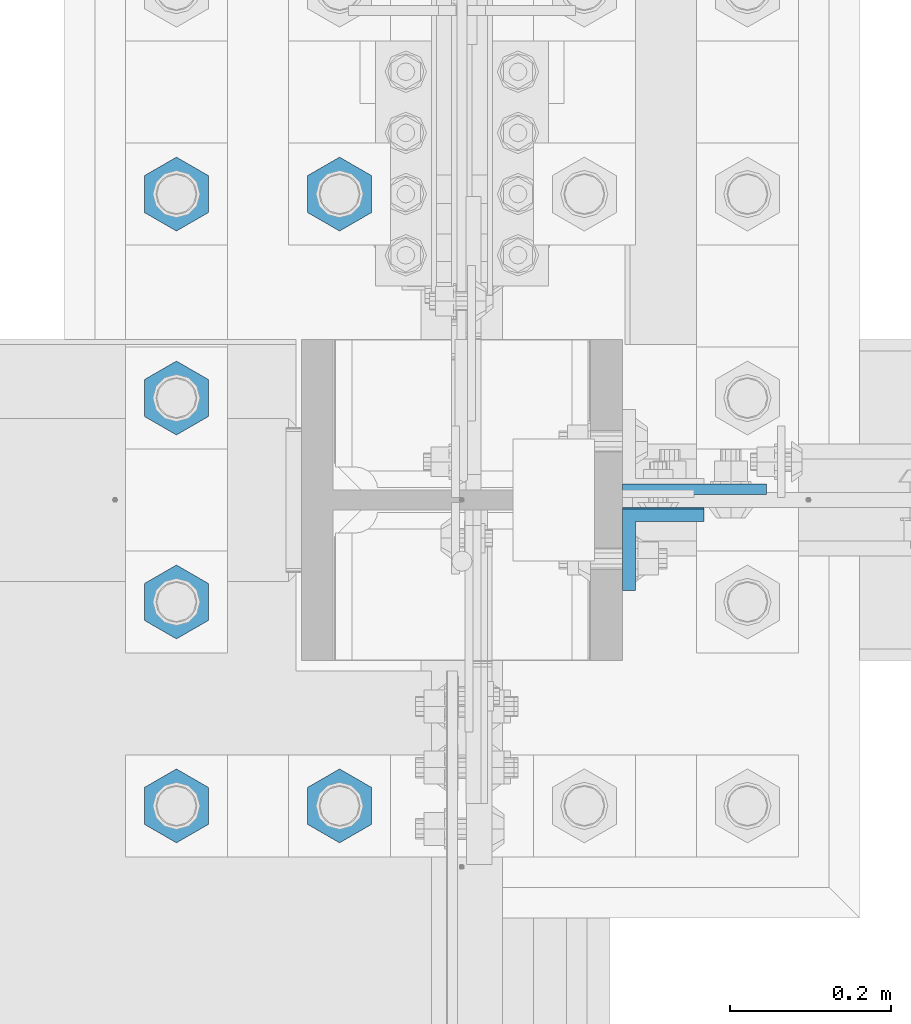
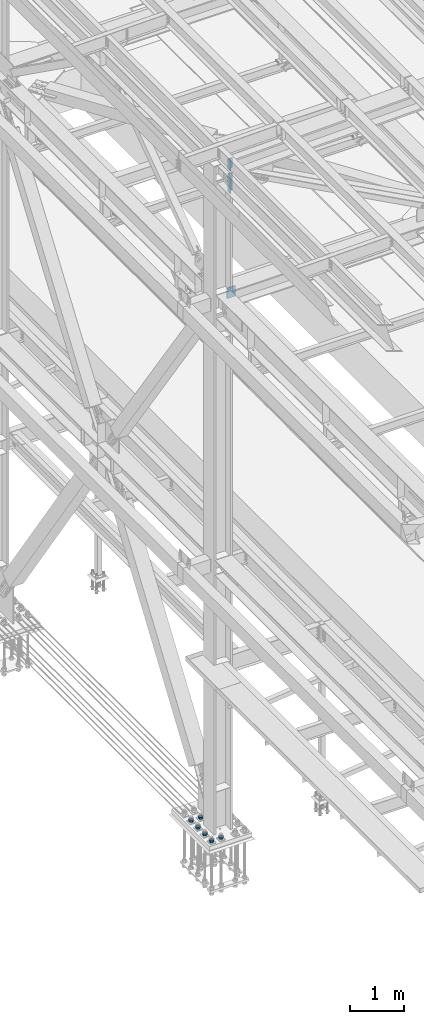
# One storey, part 1547 of 3843: 9 columns, 3 elements without a shape of their own.
"""IFC2X3 building model written with IfcOpenShell, lengths in millimetres."""

from ifc_helpers import new_model, si_unit, frame, origin_with_axes, place, context, subcontext, project, spatial, faceted_brep, material, type_object, element, aggregate, save


model = new_model("IFC2X3")

# Units and contexts
model_context = context("Model", 3, precision=1e-05, world=origin_with_axes())
body_context = subcontext(model_context, "Body", "Model", "MODEL_VIEW")
ifc_project = project(units=[si_unit("LENGTHUNIT", "METRE", prefix="MILLI"), si_unit("AREAUNIT", "SQUARE_METRE"), si_unit("VOLUMEUNIT", "CUBIC_METRE"), si_unit("MASSUNIT", "GRAM", prefix="KILO"), si_unit("TIMEUNIT", "SECOND"), si_unit("PLANEANGLEUNIT", "RADIAN"), si_unit("SOLIDANGLEUNIT", "STERADIAN"), si_unit("THERMODYNAMICTEMPERATUREUNIT", "DEGREE_CELSIUS"), si_unit("LUMINOUSINTENSITYUNIT", "LUMEN")], contexts=[model_context])

# Site, building, storey
site_placement = place(None, origin_with_axes())
site = spatial("IfcSite", under=ifc_project, at=site_placement, CompositionType="ELEMENT")
building_placement = place(site_placement, origin_with_axes())
building = spatial("IfcBuilding", under=site, at=building_placement, Name="Undefined", CompositionType="ELEMENT")
storey_placement = place(building_placement, origin_with_axes())
storey = spatial("IfcBuildingStorey", under=building, at=storey_placement, Name="Undefined", CompositionType="ELEMENT", Elevation=0.0)

# Assembly, columns
assembly_1_placement = place(storey_placement, origin_with_axes())
assembly_1 = element("IfcElementAssembly", 1, at=assembly_1_placement, inside=storey, Name="BEAM", AssemblyPlace="NOTDEFINED", PredefinedType="RIGID_FRAME")
ifc_material = material(Name="STEEL/A572-50")
column_type_1 = type_object("IfcColumnType", Name="L4X4X5/8", PredefinedType="NOTDEFINED")
column_1_placement = place(assembly_1_placement, frame((36826.8250000141, 67209.9879995346, 45113.5459635213), z_axis=(0.0, -1.0, 0.0), x_axis=(0.0, 0.0, 1.0)))
column_1 = element("IfcColumn", 2, at=column_1_placement, type_object=column_type_1, material=ifc_material, Name="ANGLE", ObjectType="L4X4X5/8", context=body_context, shape_type="Brep", body=[
    faceted_brep([(0.0, 50.8000000000029, -50.8000000000029), (0.0, 50.8000000000029, 50.8000000000029), (228.600164820818, 50.8000000000029, 50.8000000000029), (228.600164820818, 50.8000000000029, -50.8000000000029), (0.0, 34.9250000000029, 50.8000000000029), (228.600164820818, 34.9250000000029, 50.8000000000029), (0.0, 34.9250000000029, -34.9250000000029), (228.600164820818, 34.9250000000029, -34.9250000000029), (0.0, -50.8000000000029, -34.9250000000029), (228.600164820818, -50.8000000000029, -34.9250000000029), (0.0, -50.8000000000029, -50.8000000000029), (228.600164820818, -50.8000000000029, -50.8000000000029)], [[[0, 1, 2, 3]], [[1, 4, 5, 2]], [[4, 6, 7, 5]], [[6, 8, 9, 7]], [[8, 10, 11, 9]], [[10, 0, 3, 11]], [[5, 7, 9, 11, 3, 2]], [[10, 8, 6, 4, 1, 0]]]),
])
column_2_placement = place(assembly_1_placement, frame((36826.8249999999, 67211.5750003815, 44597.8922976153), z_axis=(0.0, -1.0, 0.0), x_axis=(0.0, 0.0, 1.0)))
column_2 = element("IfcColumn", 3, at=column_2_placement, type_object=column_type_1, material=ifc_material, Name="ANGLE", ObjectType="L4X4X5/8", context=body_context, shape_type="Brep", body=[
    faceted_brep([(0.0, 50.8000000000029, -50.8000000000029), (0.0, 50.8000000000029, 50.8000000000029), (406.399999999841, 50.799999998344, 50.8000000000029), (406.399999999841, 50.799999998344, -50.8000000000029), (0.0, 34.9250000000029, 50.8000000000029), (406.399999999892, 34.924999998344, 50.8000000000029), (0.0, 34.9250000000029, -34.9250000000029), (406.399999999892, 34.924999998344, -34.9250000000029), (0.0, -50.8000000000029, -34.9250000000029), (406.400000000162, -50.8000000016473, -34.9250000000029), (0.0, -50.8000000000029, -50.8000000000029), (406.400000000162, -50.8000000016473, -50.8000000000029)], [[[0, 1, 2, 3]], [[1, 4, 5, 2]], [[4, 6, 7, 5]], [[6, 8, 9, 7]], [[8, 10, 11, 9]], [[10, 0, 3, 11]], [[5, 7, 9, 11, 3, 2]], [[10, 8, 6, 4, 1, 0]]]),
])
aggregate(assembly_1, [column_1, column_2])

# Assembly, column
assembly_2_placement = place(storey_placement, origin_with_axes())
assembly_2 = element("IfcElementAssembly", 4, at=assembly_2_placement, inside=storey, Name="COLUMN", AssemblyPlace="NOTDEFINED", PredefinedType="RIGID_FRAME")
column_type_2 = type_object("IfcColumnType", PredefinedType="NOTDEFINED")
column_3_placement = place(assembly_2_placement, frame((36865.6955000011, 67285.39375, 42133.8327920583), z_axis=(-1.0, 0.0, 0.0), x_axis=(0.0, 0.0, 1.0)))
column_3 = element("IfcColumn", 5, at=column_3_placement, type_object=column_type_2, material=ifc_material, Name="PLATE", context=body_context, shape_type="Brep", body=[
    faceted_brep([(0.0, 6.35000000000582, -89.6705000000002), (0.0, 6.35000000000582, 89.6705000000002), (241.299999999996, 6.35000000000582, 89.6705000000002), (241.299999999996, 6.35000000000582, -89.6705000000002), (0.0, -6.35000000000582, 89.6705000000002), (241.299999999996, -6.35000000000582, 89.6705000000002), (0.0, -6.35000000000582, -89.6705000000002), (241.299999999996, -6.35000000000582, -89.6705000000002)], [[[0, 1, 2, 3]], [[1, 4, 5, 2]], [[4, 6, 7, 5]], [[6, 0, 3, 7]], [[5, 7, 3, 2]], [[6, 4, 1, 0]]]),
])
aggregate(assembly_2, [column_3])

# Assembly, columns
assembly_3_placement = place(storey_placement, origin_with_axes())
assembly_3 = element("IfcElementAssembly", 6, at=assembly_3_placement, inside=storey, Name="TEMPLATE", AssemblyPlace="NOTDEFINED", PredefinedType="RIGID_FRAME")
column_type_3 = type_object("IfcColumnType", Name="2_HEAVY_HEX_NUT", PredefinedType="NOTDEFINED")
column_4_placement = place(assembly_3_placement, frame((36423.6, 66890.9, 30232.35), z_axis=(1.0, 0.0, 0.0), x_axis=(0.0, 0.0, -1.0)))
column_4 = element("IfcColumn", 7, at=column_4_placement, type_object=column_type_3, material=ifc_material, Name="NUT", ObjectType="2_HEAVY_HEX_NUT", context=body_context, shape_type="Brep", body=[
    faceted_brep([(0.0, -46.0369987487793, 0.0), (0.0, -23.0184993743896, -39.869213104248), (50.7999999999993, -23.0184993743896, -39.869213104248), (50.7999999999993, -46.0369987487793, 0.0), (0.0, 23.0184993743896, -39.869213104248), (50.7999999999993, 23.0184993743896, -39.869213104248), (0.0, 46.0369987487793, 0.0), (50.7999999999993, 46.0369987487793, 0.0), (0.0, 23.0184993743896, 39.869213104248), (50.7999999999993, 23.0184993743896, 39.869213104248), (0.0, -23.0184993743896, 39.869213104248), (50.7999999999993, -23.0184993743896, 39.869213104248), (0.0, 0.0, 26.1940002441406), (0.0, 11.3650617044477, 23.5999013092805), (50.7999999999993, 11.3650617044477, 23.5999013092805), (50.7999999999993, 0.0, 26.1940002441406), (0.0, 20.4791109456419, 16.3316083006721), (50.7999999999993, 20.4791109456419, 16.3316083006721), (0.0, 25.5370200498292, 5.82867859874386), (50.7999999999993, 25.5370200498292, 5.82867859874386), (0.0, 25.5370200498292, -5.82867859874386), (50.7999999999993, 25.5370200498292, -5.82867859874386), (0.0, 20.4791109456419, -16.3316083006721), (50.7999999999993, 20.4791109456419, -16.3316083006721), (0.0, 11.3650617044477, -23.5999013092805), (50.7999999999993, 11.3650617044477, -23.5999013092805), (0.0, 0.0, -26.1940002441406), (50.7999999999993, 0.0, -26.1940002441406), (0.0, -11.3650617044477, -23.5999013092805), (50.7999999999993, -11.3650617044477, -23.5999013092805), (0.0, -20.4791109456419, -16.3316083006721), (50.7999999999993, -20.4791109456419, -16.3316083006721), (0.0, -25.5370200498292, -5.82867859874386), (50.7999999999993, -25.5370200498292, -5.82867859874386), (0.0, -25.5370200498292, 5.82867859874386), (50.7999999999993, -25.5370200498292, 5.82867859874386), (0.0, -20.4791109456419, 16.3316083006721), (50.7999999999993, -20.4791109456419, 16.3316083006721), (0.0, -11.3650617044477, 23.5999013092805), (50.7999999999993, -11.3650617044477, 23.5999013092805)], [[[0, 1, 2, 3]], [[1, 4, 5, 2]], [[4, 6, 7, 5]], [[6, 8, 9, 7]], [[8, 10, 11, 9]], [[10, 0, 3, 11]], [[12, 13, 14, 15]], [[13, 16, 17, 14]], [[16, 18, 19, 17]], [[18, 20, 21, 19]], [[20, 22, 23, 21]], [[22, 24, 25, 23]], [[24, 26, 27, 25]], [[26, 28, 29, 27]], [[28, 30, 31, 29]], [[30, 32, 33, 31]], [[32, 34, 35, 33]], [[34, 36, 37, 35]], [[36, 38, 39, 37]], [[38, 12, 15, 39]], [[5, 7, 9, 11, 3, 2], [17, 19, 21, 23, 25, 27, 29, 31, 33, 35, 37, 39, 15, 14]], [[10, 8, 6, 4, 1, 0], [38, 36, 34, 32, 30, 28, 26, 24, 22, 20, 18, 16, 13, 12]]]),
])
column_5_placement = place(assembly_3_placement, frame((36423.6, 67652.9, 30232.35), z_axis=(-1.0, 0.0, 0.0), x_axis=(0.0, 0.0, -1.0)))
column_5 = element("IfcColumn", 8, at=column_5_placement, type_object=column_type_3, material=ifc_material, Name="NUT", ObjectType="2_HEAVY_HEX_NUT", context=body_context, shape_type="Brep", body=[
    faceted_brep([(0.0, -46.0369987487793, 0.0), (0.0, -23.0184993743896, -39.869213104248), (50.7999999999993, -23.0184993743896, -39.869213104248), (50.7999999999993, -46.0369987487793, 0.0), (0.0, 23.0184993743896, -39.869213104248), (50.7999999999993, 23.0184993743896, -39.869213104248), (0.0, 46.0369987487793, 0.0), (50.7999999999993, 46.0369987487793, 0.0), (0.0, 23.0184993743896, 39.869213104248), (50.7999999999993, 23.0184993743896, 39.869213104248), (0.0, -23.0184993743896, 39.869213104248), (50.7999999999993, -23.0184993743896, 39.869213104248), (0.0, 0.0, 26.1940002441406), (0.0, 11.3650617044477, 23.5999013092805), (50.7999999999993, 11.3650617044477, 23.5999013092805), (50.7999999999993, 0.0, 26.1940002441406), (0.0, 20.4791109456419, 16.3316083006721), (50.7999999999993, 20.4791109456419, 16.3316083006721), (0.0, 25.5370200498292, 5.82867859874386), (50.7999999999993, 25.5370200498292, 5.82867859874386), (0.0, 25.5370200498292, -5.82867859874386), (50.7999999999993, 25.5370200498292, -5.82867859874386), (0.0, 20.4791109456419, -16.3316083006721), (50.7999999999993, 20.4791109456419, -16.3316083006721), (0.0, 11.3650617044477, -23.5999013092805), (50.7999999999993, 11.3650617044477, -23.5999013092805), (0.0, 0.0, -26.1940002441406), (50.7999999999993, 0.0, -26.1940002441406), (0.0, -11.3650617044477, -23.5999013092805), (50.7999999999993, -11.3650617044477, -23.5999013092805), (0.0, -20.4791109456419, -16.3316083006721), (50.7999999999993, -20.4791109456419, -16.3316083006721), (0.0, -25.5370200498292, -5.82867859874386), (50.7999999999993, -25.5370200498292, -5.82867859874386), (0.0, -25.5370200498292, 5.82867859874386), (50.7999999999993, -25.5370200498292, 5.82867859874386), (0.0, -20.4791109456419, 16.3316083006721), (50.7999999999993, -20.4791109456419, 16.3316083006721), (0.0, -11.3650617044477, 23.5999013092805), (50.7999999999993, -11.3650617044477, 23.5999013092805)], [[[0, 1, 2, 3]], [[1, 4, 5, 2]], [[4, 6, 7, 5]], [[6, 8, 9, 7]], [[8, 10, 11, 9]], [[10, 0, 3, 11]], [[12, 13, 14, 15]], [[13, 16, 17, 14]], [[16, 18, 19, 17]], [[18, 20, 21, 19]], [[20, 22, 23, 21]], [[22, 24, 25, 23]], [[24, 26, 27, 25]], [[26, 28, 29, 27]], [[28, 30, 31, 29]], [[30, 32, 33, 31]], [[32, 34, 35, 33]], [[34, 36, 37, 35]], [[36, 38, 39, 37]], [[38, 12, 15, 39]], [[5, 7, 9, 11, 3, 2], [17, 19, 21, 23, 25, 27, 29, 31, 33, 35, 37, 39, 15, 14]], [[10, 8, 6, 4, 1, 0], [38, 36, 34, 32, 30, 28, 26, 24, 22, 20, 18, 16, 13, 12]]]),
])
column_6_placement = place(assembly_3_placement, frame((36220.4, 66890.9, 30232.35), z_axis=(1.0, 0.0, 0.0), x_axis=(0.0, 0.0, -1.0)))
column_6 = element("IfcColumn", 9, at=column_6_placement, type_object=column_type_3, material=ifc_material, Name="NUT", ObjectType="2_HEAVY_HEX_NUT", context=body_context, shape_type="Brep", body=[
    faceted_brep([(0.0, -46.0369987487793, 0.0), (0.0, -23.0184993743896, -39.869213104248), (50.7999999999993, -23.0184993743896, -39.869213104248), (50.7999999999993, -46.0369987487793, 0.0), (0.0, 23.0184993743896, -39.869213104248), (50.7999999999993, 23.0184993743896, -39.869213104248), (0.0, 46.0369987487793, 0.0), (50.7999999999993, 46.0369987487793, 0.0), (0.0, 23.0184993743896, 39.869213104248), (50.7999999999993, 23.0184993743896, 39.869213104248), (0.0, -23.0184993743896, 39.869213104248), (50.7999999999993, -23.0184993743896, 39.869213104248), (0.0, 0.0, 26.1940002441406), (0.0, 11.3650617044477, 23.5999013092805), (50.7999999999993, 11.3650617044477, 23.5999013092805), (50.7999999999993, 0.0, 26.1940002441406), (0.0, 20.4791109456419, 16.3316083006721), (50.7999999999993, 20.4791109456419, 16.3316083006721), (0.0, 25.5370200498292, 5.82867859874386), (50.7999999999993, 25.5370200498292, 5.82867859874386), (0.0, 25.5370200498292, -5.82867859874386), (50.7999999999993, 25.5370200498292, -5.82867859874386), (0.0, 20.4791109456419, -16.3316083006721), (50.7999999999993, 20.4791109456419, -16.3316083006721), (0.0, 11.3650617044477, -23.5999013092805), (50.7999999999993, 11.3650617044477, -23.5999013092805), (0.0, 0.0, -26.1940002441406), (50.7999999999993, 0.0, -26.1940002441406), (0.0, -11.3650617044477, -23.5999013092805), (50.7999999999993, -11.3650617044477, -23.5999013092805), (0.0, -20.4791109456419, -16.3316083006721), (50.7999999999993, -20.4791109456419, -16.3316083006721), (0.0, -25.5370200498292, -5.82867859874386), (50.7999999999993, -25.5370200498292, -5.82867859874386), (0.0, -25.5370200498292, 5.82867859874386), (50.7999999999993, -25.5370200498292, 5.82867859874386), (0.0, -20.4791109456419, 16.3316083006721), (50.7999999999993, -20.4791109456419, 16.3316083006721), (0.0, -11.3650617044477, 23.5999013092805), (50.7999999999993, -11.3650617044477, 23.5999013092805)], [[[0, 1, 2, 3]], [[1, 4, 5, 2]], [[4, 6, 7, 5]], [[6, 8, 9, 7]], [[8, 10, 11, 9]], [[10, 0, 3, 11]], [[12, 13, 14, 15]], [[13, 16, 17, 14]], [[16, 18, 19, 17]], [[18, 20, 21, 19]], [[20, 22, 23, 21]], [[22, 24, 25, 23]], [[24, 26, 27, 25]], [[26, 28, 29, 27]], [[28, 30, 31, 29]], [[30, 32, 33, 31]], [[32, 34, 35, 33]], [[34, 36, 37, 35]], [[36, 38, 39, 37]], [[38, 12, 15, 39]], [[5, 7, 9, 11, 3, 2], [17, 19, 21, 23, 25, 27, 29, 31, 33, 35, 37, 39, 15, 14]], [[10, 8, 6, 4, 1, 0], [38, 36, 34, 32, 30, 28, 26, 24, 22, 20, 18, 16, 13, 12]]]),
])
column_7_placement = place(assembly_3_placement, frame((36220.4, 67144.9, 30232.35), z_axis=(1.0, 0.0, 0.0), x_axis=(0.0, 0.0, -1.0)))
column_7 = element("IfcColumn", 10, at=column_7_placement, type_object=column_type_3, material=ifc_material, Name="NUT", ObjectType="2_HEAVY_HEX_NUT", context=body_context, shape_type="Brep", body=[
    faceted_brep([(0.0, -46.0369987487793, 0.0), (0.0, -23.0184993743896, -39.869213104248), (50.7999999999993, -23.0184993743896, -39.869213104248), (50.7999999999993, -46.0369987487793, 0.0), (0.0, 23.0184993743896, -39.869213104248), (50.7999999999993, 23.0184993743896, -39.869213104248), (0.0, 46.0369987487793, 0.0), (50.7999999999993, 46.0369987487793, 0.0), (0.0, 23.0184993743896, 39.869213104248), (50.7999999999993, 23.0184993743896, 39.869213104248), (0.0, -23.0184993743896, 39.869213104248), (50.7999999999993, -23.0184993743896, 39.869213104248), (0.0, 0.0, 26.1940002441406), (0.0, 11.3650617044477, 23.5999013092805), (50.7999999999993, 11.3650617044477, 23.5999013092805), (50.7999999999993, 0.0, 26.1940002441406), (0.0, 20.4791109456419, 16.3316083006721), (50.7999999999993, 20.4791109456419, 16.3316083006721), (0.0, 25.5370200498292, 5.82867859874386), (50.7999999999993, 25.5370200498292, 5.82867859874386), (0.0, 25.5370200498292, -5.82867859874386), (50.7999999999993, 25.5370200498292, -5.82867859874386), (0.0, 20.4791109456419, -16.3316083006721), (50.7999999999993, 20.4791109456419, -16.3316083006721), (0.0, 11.3650617044477, -23.5999013092805), (50.7999999999993, 11.3650617044477, -23.5999013092805), (0.0, 0.0, -26.1940002441406), (50.7999999999993, 0.0, -26.1940002441406), (0.0, -11.3650617044477, -23.5999013092805), (50.7999999999993, -11.3650617044477, -23.5999013092805), (0.0, -20.4791109456419, -16.3316083006721), (50.7999999999993, -20.4791109456419, -16.3316083006721), (0.0, -25.5370200498292, -5.82867859874386), (50.7999999999993, -25.5370200498292, -5.82867859874386), (0.0, -25.5370200498292, 5.82867859874386), (50.7999999999993, -25.5370200498292, 5.82867859874386), (0.0, -20.4791109456419, 16.3316083006721), (50.7999999999993, -20.4791109456419, 16.3316083006721), (0.0, -11.3650617044477, 23.5999013092805), (50.7999999999993, -11.3650617044477, 23.5999013092805)], [[[0, 1, 2, 3]], [[1, 4, 5, 2]], [[4, 6, 7, 5]], [[6, 8, 9, 7]], [[8, 10, 11, 9]], [[10, 0, 3, 11]], [[12, 13, 14, 15]], [[13, 16, 17, 14]], [[16, 18, 19, 17]], [[18, 20, 21, 19]], [[20, 22, 23, 21]], [[22, 24, 25, 23]], [[24, 26, 27, 25]], [[26, 28, 29, 27]], [[28, 30, 31, 29]], [[30, 32, 33, 31]], [[32, 34, 35, 33]], [[34, 36, 37, 35]], [[36, 38, 39, 37]], [[38, 12, 15, 39]], [[5, 7, 9, 11, 3, 2], [17, 19, 21, 23, 25, 27, 29, 31, 33, 35, 37, 39, 15, 14]], [[10, 8, 6, 4, 1, 0], [38, 36, 34, 32, 30, 28, 26, 24, 22, 20, 18, 16, 13, 12]]]),
])
column_8_placement = place(assembly_3_placement, frame((36220.4, 67398.9, 30232.35), z_axis=(1.0, 0.0, 0.0), x_axis=(0.0, 0.0, -1.0)))
column_8 = element("IfcColumn", 11, at=column_8_placement, type_object=column_type_3, material=ifc_material, Name="NUT", ObjectType="2_HEAVY_HEX_NUT", context=body_context, shape_type="Brep", body=[
    faceted_brep([(0.0, -46.0369987487793, 0.0), (0.0, -23.0184993743896, -39.869213104248), (50.7999999999993, -23.0184993743896, -39.869213104248), (50.7999999999993, -46.0369987487793, 0.0), (0.0, 23.0184993743896, -39.869213104248), (50.7999999999993, 23.0184993743896, -39.869213104248), (0.0, 46.0369987487793, 0.0), (50.7999999999993, 46.0369987487793, 0.0), (0.0, 23.0184993743896, 39.869213104248), (50.7999999999993, 23.0184993743896, 39.869213104248), (0.0, -23.0184993743896, 39.869213104248), (50.7999999999993, -23.0184993743896, 39.869213104248), (0.0, 0.0, 26.1940002441406), (0.0, 11.3650617044477, 23.5999013092805), (50.7999999999993, 11.3650617044477, 23.5999013092805), (50.7999999999993, 0.0, 26.1940002441406), (0.0, 20.4791109456419, 16.3316083006721), (50.7999999999993, 20.4791109456419, 16.3316083006721), (0.0, 25.5370200498292, 5.82867859874386), (50.7999999999993, 25.5370200498292, 5.82867859874386), (0.0, 25.5370200498292, -5.82867859874386), (50.7999999999993, 25.5370200498292, -5.82867859874386), (0.0, 20.4791109456419, -16.3316083006721), (50.7999999999993, 20.4791109456419, -16.3316083006721), (0.0, 11.3650617044477, -23.5999013092805), (50.7999999999993, 11.3650617044477, -23.5999013092805), (0.0, 0.0, -26.1940002441406), (50.7999999999993, 0.0, -26.1940002441406), (0.0, -11.3650617044477, -23.5999013092805), (50.7999999999993, -11.3650617044477, -23.5999013092805), (0.0, -20.4791109456419, -16.3316083006721), (50.7999999999993, -20.4791109456419, -16.3316083006721), (0.0, -25.5370200498292, -5.82867859874386), (50.7999999999993, -25.5370200498292, -5.82867859874386), (0.0, -25.5370200498292, 5.82867859874386), (50.7999999999993, -25.5370200498292, 5.82867859874386), (0.0, -20.4791109456419, 16.3316083006721), (50.7999999999993, -20.4791109456419, 16.3316083006721), (0.0, -11.3650617044477, 23.5999013092805), (50.7999999999993, -11.3650617044477, 23.5999013092805)], [[[0, 1, 2, 3]], [[1, 4, 5, 2]], [[4, 6, 7, 5]], [[6, 8, 9, 7]], [[8, 10, 11, 9]], [[10, 0, 3, 11]], [[12, 13, 14, 15]], [[13, 16, 17, 14]], [[16, 18, 19, 17]], [[18, 20, 21, 19]], [[20, 22, 23, 21]], [[22, 24, 25, 23]], [[24, 26, 27, 25]], [[26, 28, 29, 27]], [[28, 30, 31, 29]], [[30, 32, 33, 31]], [[32, 34, 35, 33]], [[34, 36, 37, 35]], [[36, 38, 39, 37]], [[38, 12, 15, 39]], [[5, 7, 9, 11, 3, 2], [17, 19, 21, 23, 25, 27, 29, 31, 33, 35, 37, 39, 15, 14]], [[10, 8, 6, 4, 1, 0], [38, 36, 34, 32, 30, 28, 26, 24, 22, 20, 18, 16, 13, 12]]]),
])
column_9_placement = place(assembly_3_placement, frame((36220.4, 67652.9, 30232.35), z_axis=(-1.0, 0.0, 0.0), x_axis=(0.0, 0.0, -1.0)))
column_9 = element("IfcColumn", 12, at=column_9_placement, type_object=column_type_3, material=ifc_material, Name="NUT", ObjectType="2_HEAVY_HEX_NUT", context=body_context, shape_type="Brep", body=[
    faceted_brep([(0.0, -46.0369987487793, 0.0), (0.0, -23.0184993743896, -39.869213104248), (50.7999999999993, -23.0184993743896, -39.869213104248), (50.7999999999993, -46.0369987487793, 0.0), (0.0, 23.0184993743896, -39.869213104248), (50.7999999999993, 23.0184993743896, -39.869213104248), (0.0, 46.0369987487793, 0.0), (50.7999999999993, 46.0369987487793, 0.0), (0.0, 23.0184993743896, 39.869213104248), (50.7999999999993, 23.0184993743896, 39.869213104248), (0.0, -23.0184993743896, 39.869213104248), (50.7999999999993, -23.0184993743896, 39.869213104248), (0.0, 0.0, 26.1940002441406), (0.0, 11.3650617044477, 23.5999013092805), (50.7999999999993, 11.3650617044477, 23.5999013092805), (50.7999999999993, 0.0, 26.1940002441406), (0.0, 20.4791109456419, 16.3316083006721), (50.7999999999993, 20.4791109456419, 16.3316083006721), (0.0, 25.5370200498292, 5.82867859874386), (50.7999999999993, 25.5370200498292, 5.82867859874386), (0.0, 25.5370200498292, -5.82867859874386), (50.7999999999993, 25.5370200498292, -5.82867859874386), (0.0, 20.4791109456419, -16.3316083006721), (50.7999999999993, 20.4791109456419, -16.3316083006721), (0.0, 11.3650617044477, -23.5999013092805), (50.7999999999993, 11.3650617044477, -23.5999013092805), (0.0, 0.0, -26.1940002441406), (50.7999999999993, 0.0, -26.1940002441406), (0.0, -11.3650617044477, -23.5999013092805), (50.7999999999993, -11.3650617044477, -23.5999013092805), (0.0, -20.4791109456419, -16.3316083006721), (50.7999999999993, -20.4791109456419, -16.3316083006721), (0.0, -25.5370200498292, -5.82867859874386), (50.7999999999993, -25.5370200498292, -5.82867859874386), (0.0, -25.5370200498292, 5.82867859874386), (50.7999999999993, -25.5370200498292, 5.82867859874386), (0.0, -20.4791109456419, 16.3316083006721), (50.7999999999993, -20.4791109456419, 16.3316083006721), (0.0, -11.3650617044477, 23.5999013092805), (50.7999999999993, -11.3650617044477, 23.5999013092805)], [[[0, 1, 2, 3]], [[1, 4, 5, 2]], [[4, 6, 7, 5]], [[6, 8, 9, 7]], [[8, 10, 11, 9]], [[10, 0, 3, 11]], [[12, 13, 14, 15]], [[13, 16, 17, 14]], [[16, 18, 19, 17]], [[18, 20, 21, 19]], [[20, 22, 23, 21]], [[22, 24, 25, 23]], [[24, 26, 27, 25]], [[26, 28, 29, 27]], [[28, 30, 31, 29]], [[30, 32, 33, 31]], [[32, 34, 35, 33]], [[34, 36, 37, 35]], [[36, 38, 39, 37]], [[38, 12, 15, 39]], [[5, 7, 9, 11, 3, 2], [17, 19, 21, 23, 25, 27, 29, 31, 33, 35, 37, 39, 15, 14]], [[10, 8, 6, 4, 1, 0], [38, 36, 34, 32, 30, 28, 26, 24, 22, 20, 18, 16, 13, 12]]]),
])
aggregate(assembly_3, [column_4, column_5, column_6, column_7, column_8, column_9])

save(model, "model.ifc")
